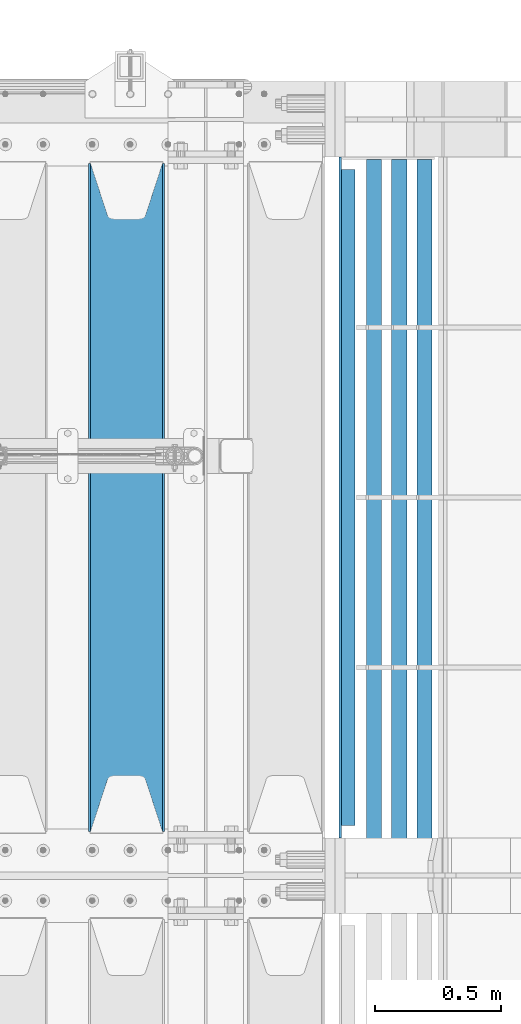
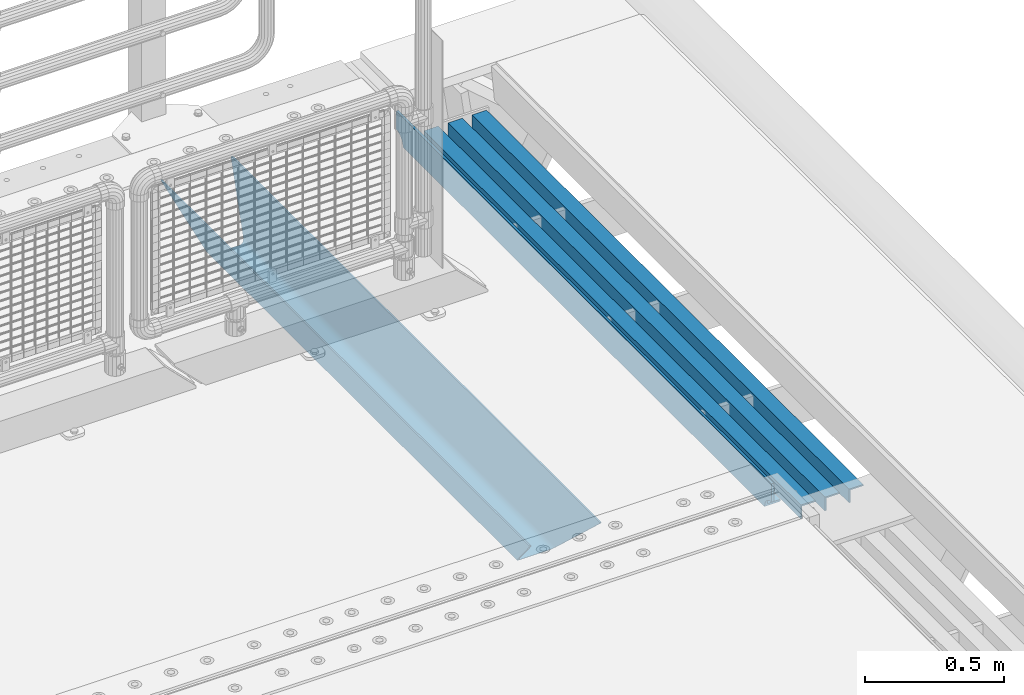
# One storey, part 135 of 257: 5 beams.
"""IFC2X3 building model written with IfcOpenShell, lengths in millimetres."""

from ifc_helpers import new_model, si_unit, frame, origin_with_axes, place, context, subcontext, project, spatial, faceted_brep, material, type_object, element, save


model = new_model("IFC2X3")

# Units and contexts
model_context = context("Model", 3, precision=1e-05, world=origin_with_axes())
body_context = subcontext(model_context, "Body", "Model", "MODEL_VIEW")
ifc_project = project(units=[si_unit("LENGTHUNIT", "METRE", prefix="MILLI"), si_unit("AREAUNIT", "SQUARE_METRE"), si_unit("VOLUMEUNIT", "CUBIC_METRE"), si_unit("MASSUNIT", "GRAM", prefix="KILO"), si_unit("TIMEUNIT", "SECOND"), si_unit("PLANEANGLEUNIT", "RADIAN"), si_unit("SOLIDANGLEUNIT", "STERADIAN"), si_unit("THERMODYNAMICTEMPERATUREUNIT", "DEGREE_CELSIUS"), si_unit("LUMINOUSINTENSITYUNIT", "LUMEN")], contexts=[model_context])

# Site, building, storey
site_placement = place(None, origin_with_axes())
site = spatial("IfcSite", under=ifc_project, at=site_placement, CompositionType="ELEMENT")
building_placement = place(site_placement, origin_with_axes())
building = spatial("IfcBuilding", under=site, at=building_placement, Name="Standard", CompositionType="ELEMENT")
storey_placement = place(building_placement, origin_with_axes())
storey = spatial("IfcBuildingStorey", under=building, at=storey_placement, Name="Undefined", CompositionType="ELEMENT", Elevation=0.0)

# Beams
ifc_material_1 = material(Name="STEEL/S355N")
beam_type_1 = type_object("IfcBeamType", PredefinedType="NOTDEFINED")
beam_1_placement = place(storey_placement, frame((58480.0, 9175.0, -115.0), z_axis=(0.0, 0.0, 1.0), x_axis=(0.0, 1.0, 0.0)))
element("IfcBeam", 1, at=beam_1_placement, inside=storey, type_object=beam_type_1, material=ifc_material_1, context=body_context, shape_type="Brep", body=[
    faceted_brep([(0.0, 150.0, 115.0), (0.0, 143.690000000002, 115.0), (2650.00000000297, 143.690000000002, 115.0), (2650.00000000297, 150.0, 115.0), (2650.00000000297, 142.059565218406, 110.0000000031), (2650.00000000297, 148.369565218403, 110.0000000031), (2441.90079219208, -80.1103600731149, -98.0992078077845), (2437.7588105432, -77.5672621345584, -102.241189456673), (2434.06523489746, -74.4080125315522, -105.934765102404), (2430.91086095089, -70.7102721255724, -109.089139048974), (2428.37322971128, -66.5649389910031, -111.626770288588), (2426.51472138055, -62.0739139532889, -113.485278619323), (2425.38102192091, -57.3475956567636, -114.618978078955), (2424.99999999987, -52.5021667386536, -115.0), (2424.99999999987, 52.5021667386536, -115.0), (2425.38102192091, 57.3475956567636, -114.618978078955), (2426.51472138055, 62.0739139532889, -113.485278619323), (2428.37322971128, 66.5649389910031, -111.626770288588), (2430.91086095089, 70.7102721255724, -109.089139048974), (2434.06523489746, 74.4080125315522, -105.934765102404), (2437.7588105432, 77.5672621345584, -102.241189456673), (2441.90079219208, 80.1103600731149, -98.0992078077846), (2446.38936140511, 81.9747917625791, -93.6106385947584), (2448.24948500409, 76.2713538057287, -91.7505149957729), (2444.62967112262, 74.76777986261, -95.3703288772456), (2441.28936334126, 72.7168944282894, -98.710636658607), (2438.31067330438, 70.1691124903809, -101.689326695487), (2435.76682334747, 67.1870637758839, -104.233176652398), (2433.72034654133, 63.8440531834931, -106.279653458539), (2432.22154950041, 60.2222587982324, -107.778450499454), (2431.30727574265, 56.4107117849126, -108.692724257221), (2430.99999999987, 52.5031078186876, -109.0), (2430.99999999987, -52.5031078186876, -109.0), (2431.30727574265, -56.4107117849126, -108.692724257221), (2432.22154950041, -60.2222587982324, -107.778450499454), (2433.72034654133, -63.8440531834931, -106.279653458539), (2435.76682334747, -67.1870637758839, -104.233176652398), (2438.31067330438, -70.1691124903809, -101.689326695487), (2441.28936334126, -72.7168944282894, -98.7106366586071), (2444.62967112262, -74.76777986261, -95.3703288772457), (2448.24948500409, -76.2713538057287, -91.7505149957729), (2650.00000000297, -142.059565218406, 110.0000000031), (2650.00000000297, -148.369565218403, 110.0000000031), (2446.38936140511, -81.9747917625791, -93.6106385947584), (2650.00000000297, -143.690000000002, 115.0), (2650.00000000297, -150.0, 115.0), (0.0, -143.690000000002, 115.0), (0.0, -150.0, 115.0), (0.0, -148.369565218258, 110.000000002662), (203.61063859742, -81.9747917625791, -93.6106385947584), (208.099207810447, -80.1103600731149, -98.0992078077845), (212.241189459335, -77.5672621345584, -102.241189456673), (215.934765105066, -74.4080125315522, -105.934765102404), (219.089139051636, -70.7102721255724, -109.089139048974), (221.626770291251, -66.5649389910031, -111.626770288588), (223.485278621985, -62.0739139532889, -113.485278619323), (224.618978081617, -57.3475956567636, -114.618978078955), (225.000000002662, -52.5021667386536, -115.0), (225.000000002662, 52.5021667386536, -115.0), (224.618978081617, 57.3475956567636, -114.618978078955), (223.485278621985, 62.0739139532889, -113.485278619323), (221.626770291251, 66.5649389910031, -111.626770288588), (219.089139051636, 70.7102721255724, -109.089139048974), (215.934765105066, 74.4080125315522, -105.934765102404), (212.241189459335, 77.5672621345584, -102.241189456673), (208.099207810447, 80.1103600731149, -98.0992078077846), (203.61063859742, 81.9747917625791, -93.6106385947584), (0.0, 148.369565218258, 110.000000002662), (0.0, 142.05956521826, 110.000000002662), (201.750514998435, 76.2713538057287, -91.7505149957729), (205.370328879908, 74.76777986261, -95.3703288772456), (208.710636661269, 72.7168944282894, -98.710636658607), (211.689326698149, 70.1691124903809, -101.689326695487), (214.233176655061, 67.1870637758839, -104.233176652398), (216.279653461201, 63.8440531834931, -106.279653458539), (217.778450502116, 60.2222587982324, -107.778450499454), (218.692724259884, 56.4107117849126, -108.692724257221), (219.000000002662, 52.5031078186876, -109.0), (219.000000002662, -52.5031078186876, -109.0), (218.692724259884, -56.4107117849126, -108.692724257221), (217.778450502116, -60.2222587982324, -107.778450499454), (216.279653461201, -63.8440531834931, -106.279653458539), (214.233176655061, -67.1870637758839, -104.233176652398), (211.689326698149, -70.1691124903809, -101.689326695487), (208.710636661269, -72.7168944282894, -98.7106366586071), (205.370328879908, -74.76777986261, -95.3703288772457), (201.750514998435, -76.2713538057287, -91.7505149957729), (0.0, -142.05956521826, 110.000000002662)], [[[0, 1, 2, 3]], [[3, 2, 4, 5]], [[6, 7, 8, 9, 10, 11, 12, 13, 14, 15, 16, 17, 18, 19, 20, 21, 22, 5, 4, 23, 24, 25, 26, 27, 28, 29, 30, 31, 32, 33, 34, 35, 36, 37, 38, 39, 40, 41, 42, 43]], [[44, 45, 42, 41]], [[46, 47, 45, 44]], [[43, 42, 45, 47, 48, 49]], [[6, 43, 49, 50]], [[7, 6, 50, 51]], [[8, 7, 51, 52]], [[9, 8, 52, 53]], [[10, 9, 53, 54]], [[11, 10, 54, 55]], [[12, 11, 55, 56]], [[13, 12, 56, 57]], [[14, 13, 57, 58]], [[15, 14, 58, 59]], [[16, 15, 59, 60]], [[17, 16, 60, 61]], [[18, 17, 61, 62]], [[19, 18, 62, 63]], [[20, 19, 63, 64]], [[21, 20, 64, 65]], [[22, 21, 65, 66]], [[0, 3, 5, 22, 66, 67]], [[1, 0, 67, 68]], [[23, 4, 2, 1, 68, 69]], [[24, 23, 69, 70]], [[25, 24, 70, 71]], [[26, 25, 71, 72]], [[27, 26, 72, 73]], [[28, 27, 73, 74]], [[29, 28, 74, 75]], [[30, 29, 75, 76]], [[31, 30, 76, 77]], [[32, 31, 77, 78]], [[33, 32, 78, 79]], [[34, 33, 79, 80]], [[35, 34, 80, 81]], [[36, 35, 81, 82]], [[37, 36, 82, 83]], [[38, 37, 83, 84]], [[39, 38, 84, 85]], [[40, 39, 85, 86]], [[46, 44, 41, 40, 86, 87]], [[47, 46, 87, 48]], [[86, 85, 84, 83, 82, 81, 80, 79, 78, 77, 76, 75, 74, 73, 72, 71, 70, 69, 68, 67, 66, 65, 64, 63, 62, 61, 60, 59, 58, 57, 56, 55, 54, 53, 52, 51, 50, 49, 48, 87]]]),
])
ifc_material_2 = material(Name="STEEL/S355J2")
beam_type_2 = type_object("IfcBeamType", PredefinedType="NOTDEFINED")
beam_2_placement = place(storey_placement, frame((59354.5025260065, 9150.0, -124.999999999993), z_axis=(0.0, 0.0, 1.0), x_axis=(0.0, 1.0, 0.0)))
element("IfcBeam", 2, at=beam_2_placement, inside=storey, type_object=beam_type_2, material=ifc_material_2, context=body_context, shape_type="Brep", body=[
    faceted_brep([(2700.0, 22.5, -15.0), (2684.54915028125, 22.5, -17.4471741852423), (2684.54915028125, 32.5, -17.4471741852423), (2700.0, 32.5, -15.0), (2670.61073738538, 22.5, -24.5491502812526), (2670.61073738538, 32.5, -24.5491502812526), (2659.54915028125, 22.5, -35.6107373853764), (2659.54915028125, 32.5, -35.6107373853764), (2652.44717418524, 22.5, -49.5491502812526), (2652.44717418524, 32.5, -49.5491502812526), (2651.58384440325, -32.5, -55.0), (2650.0, -32.5, -65.0), (2650.0, 32.5, -65.0), (2651.58384440325, 22.5, -55.0), (0.0, 32.5, 65.0), (0.0, 22.5, 65.0), (2700.0, 22.5, 65.0), (2700.0, 32.5, 65.0), (0.0, 32.5, -15.0), (0.0, 22.5, -15.0), (15.4508497187474, 32.5, -17.4471741852423), (15.4508497187474, 22.5, -17.4471741852423), (29.3892626146236, 32.5, -24.5491502812526), (29.3892626146236, 22.5, -24.5491502812526), (40.4508497187473, 32.5, -35.6107373853763), (40.4508497187473, 22.5, -35.6107373853763), (47.5528258147577, 32.5, -49.5491502812526), (47.5528258147577, 22.5, -49.5491502812526), (50.0, -32.5, -65.0), (48.4161555967548, -32.5, -55.0), (48.4161555967548, 22.5, -55.0), (50.0, 32.5, -65.0)], [[[0, 1, 2, 3]], [[4, 5, 2, 1]], [[6, 7, 5, 4]], [[8, 9, 7, 6]], [[10, 11, 12, 9, 8, 13]], [[14, 15, 16, 17]], [[15, 14, 18, 19]], [[19, 18, 20, 21]], [[21, 20, 22, 23]], [[23, 22, 24, 25]], [[25, 24, 26, 27]], [[28, 29, 30, 27, 26, 31]], [[30, 29, 10, 13]], [[16, 15, 19, 21, 23, 25, 27, 30, 13, 8, 6, 4, 1, 0]], [[17, 16, 0, 3]], [[5, 7, 9, 12, 31, 26, 24, 22, 20, 18, 14, 17, 3, 2]], [[28, 31, 12, 11]], [[29, 28, 11, 10]]]),
])
beam_type_3 = type_object("IfcBeamType", PredefinedType="NOTDEFINED")
for number, where, z_axis, x_axis in (
    (3, (59661.998829901, 11839.9999004142, -209.999999999564), (0.0, 0.0, -1.0), (0.0, -1.0, 0.0)),
    (4, (59561.998829901, 11839.9999004143, -209.999999999564), (0.0, 0.0, -1.0), (0.0, -1.0, 0.0)),
    (5, (59461.9988299003, 11840.0000023388, -209.999999999622), (0.0, 0.0, -1.0), (0.0, -1.0, 0.0)),
):
    element("IfcBeam", number, at=place(storey_placement, frame(where, z_axis=z_axis, x_axis=x_axis)), inside=storey, type_object=beam_type_3, material=ifc_material_2, context=body_context, shape_type="Brep", body=[
        faceted_brep([(-9.09494701772928e-13, 29.9999999999854, -29.9999999999999), (-9.09494701772928e-13, 29.9999999999854, 30.0000000000001), (2710.00017042502, 30.0, 30.0), (2710.00017042502, 30.0, -30.0), (-9.09494701772928e-13, 23.9999999999854, 30.0), (2710.00017042502, 24.0, 30.0), (-1.81898940354586e-12, 23.9999999999854, -24.0), (2710.00017042501, 24.0, -24.0), (-1.81898940354586e-12, -30.0000000000146, -24.0), (2710.00017042501, -30.0, -24.0), (-1.81898940354586e-12, -30.0000000000146, -30.0), (2710.00017042502, -30.0, -30.0)], [[[0, 1, 2, 3]], [[1, 4, 5, 2]], [[4, 6, 7, 5]], [[6, 8, 9, 7]], [[8, 10, 11, 9]], [[10, 0, 3, 11]], [[5, 7, 9, 11, 3, 2]], [[10, 8, 6, 4, 1, 0]]]),
    ])

save(model, "model.ifc")
